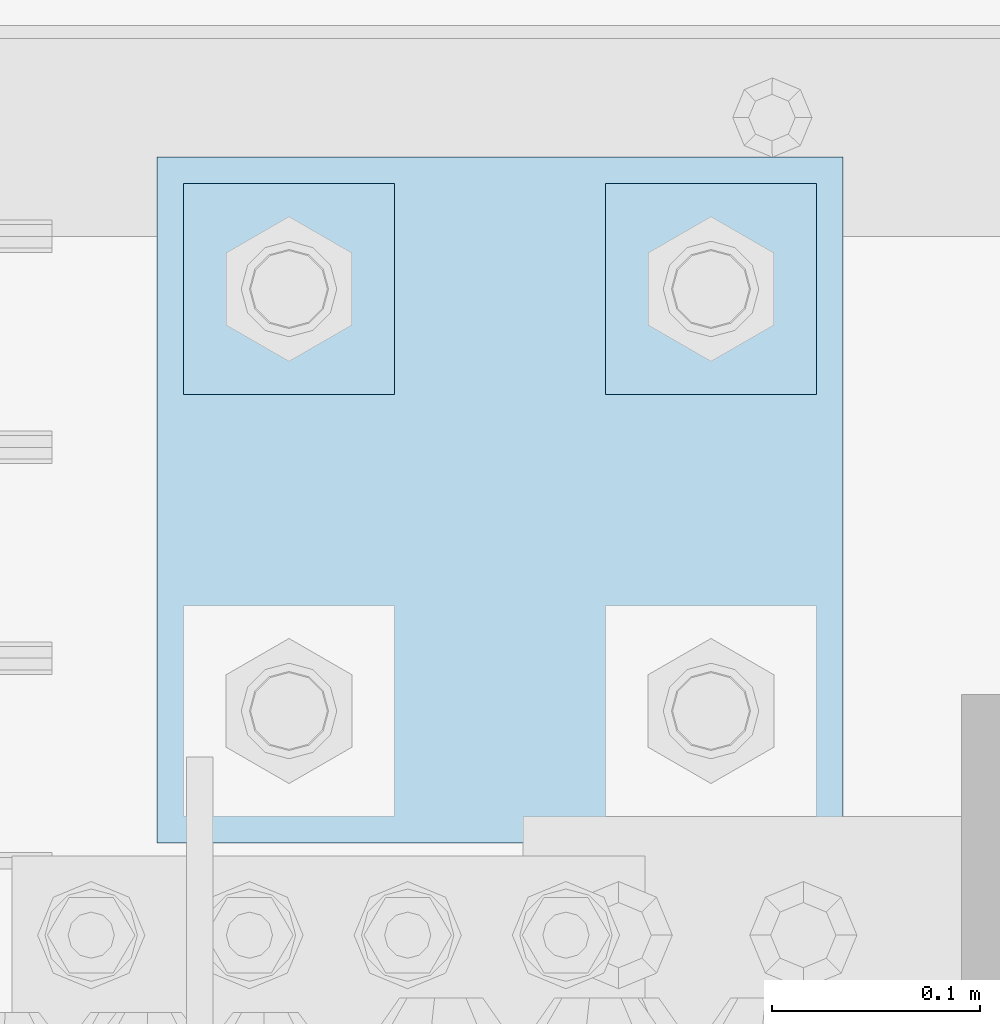
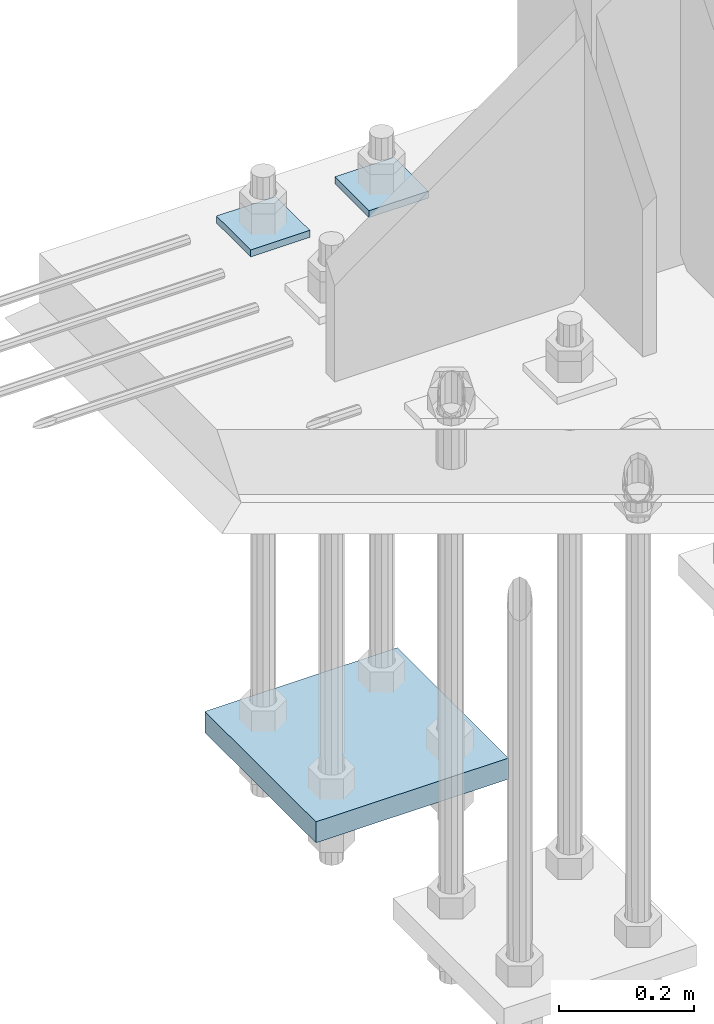
# One storey, part 3655 of 3843: 3 plates, 1 element without a shape of its own.
"""IFC2X3 building model written with IfcOpenShell, lengths in millimetres."""

from ifc_helpers import new_model, si_unit, frame, origin_with_axes, place, context, subcontext, project, spatial, faceted_brep, material, type_object, element, aggregate, save


model = new_model("IFC2X3")

# Units and contexts
model_context = context("Model", 3, precision=1e-05, world=origin_with_axes())
body_context = subcontext(model_context, "Body", "Model", "MODEL_VIEW")
ifc_project = project(units=[si_unit("LENGTHUNIT", "METRE", prefix="MILLI"), si_unit("AREAUNIT", "SQUARE_METRE"), si_unit("VOLUMEUNIT", "CUBIC_METRE"), si_unit("MASSUNIT", "GRAM", prefix="KILO"), si_unit("TIMEUNIT", "SECOND"), si_unit("PLANEANGLEUNIT", "RADIAN"), si_unit("SOLIDANGLEUNIT", "STERADIAN"), si_unit("THERMODYNAMICTEMPERATUREUNIT", "DEGREE_CELSIUS"), si_unit("LUMINOUSINTENSITYUNIT", "LUMEN")], contexts=[model_context])

# Site, building, storey
site_placement = place(None, origin_with_axes())
site = spatial("IfcSite", under=ifc_project, at=site_placement, CompositionType="ELEMENT")
building_placement = place(site_placement, origin_with_axes())
building = spatial("IfcBuilding", under=site, at=building_placement, Name="Undefined", CompositionType="ELEMENT")
storey_placement = place(building_placement, origin_with_axes())
storey = spatial("IfcBuildingStorey", under=building, at=storey_placement, Name="Undefined", CompositionType="ELEMENT", Elevation=0.0)

# Assembly, plates
assembly_placement = place(storey_placement, origin_with_axes())
assembly = element("IfcElementAssembly", 1, at=assembly_placement, inside=storey, Name="TEMPLATE", AssemblyPlace="NOTDEFINED", PredefinedType="RIGID_FRAME")
ifc_material = material(Name="STEEL/A572-50")
plate_type_1 = type_object("IfcPlateType", PredefinedType="NOTDEFINED")
plate_1_placement = place(assembly_placement, frame((85293.2, 104990.9, 29698.95), z_axis=(0.0, -1.0, 0.0), x_axis=(1.0, 0.0, 0.0)))
plate_1 = element("IfcPlate", 2, at=plate_1_placement, type_object=plate_type_1, material=ifc_material, Name="Washer Plate", context=body_context, shape_type="Brep", body=[
    faceted_brep([(0.0, -6.3499999046162, 0.0), (-1.67347025126219e-10, -6.35000000000582, 101.600000000151), (-1.67347025126219e-10, 6.35000000000582, 101.600000000151), (7.27595761418343e-12, 6.3499999046162, 0.0), (101.599998474121, -6.34999999999854, 101.599998474121), (101.599998474121, 6.34999999999854, 101.599998474121), (101.6, -6.34999999999854, 0.0), (101.6, 6.34999999999854, 0.0)], [[[0, 1, 2, 3]], [[1, 4, 5, 2]], [[4, 6, 7, 5]], [[6, 0, 3, 7]], [[5, 7, 3, 2]], [[6, 4, 1, 0]]]),
])
plate_2_placement = place(assembly_placement, frame((85090.0, 104990.9, 29698.95), z_axis=(0.0, -1.0, 0.0), x_axis=(1.0, 0.0, 0.0)))
plate_2 = element("IfcPlate", 3, at=plate_2_placement, type_object=plate_type_1, material=ifc_material, Name="Washer Plate", context=body_context, shape_type="Brep", body=[
    faceted_brep([(0.0, -6.3499999046162, 0.0), (-1.67347025126219e-10, -6.35000000000582, 101.600000000151), (-1.67347025126219e-10, 6.35000000000582, 101.600000000151), (7.27595761418343e-12, 6.3499999046162, 0.0), (101.599998474121, -6.34999999999854, 101.599998474121), (101.599998474121, 6.34999999999854, 101.599998474121), (101.6, -6.34999999999854, 0.0), (101.6, 6.34999999999854, 0.0)], [[[0, 1, 2, 3]], [[1, 4, 5, 2]], [[4, 6, 7, 5]], [[6, 0, 3, 7]], [[5, 7, 3, 2]], [[6, 4, 1, 0]]]),
])
plate_type_2 = type_object("IfcPlateType", PredefinedType="NOTDEFINED")
plate_3_placement = place(assembly_placement, frame((85077.3, 105003.600003052, 28784.55), z_axis=(1.0, 0.0, 0.0), x_axis=(0.0, -1.0, 0.0)))
plate_3 = element("IfcPlate", 4, at=plate_3_placement, type_object=plate_type_2, material=ifc_material, Name="PLATE", context=body_context, shape_type="Brep", body=[
    faceted_brep([(0.0, -19.0500000000029, 0.0), (0.0, -19.0499999999993, 330.200012207031), (0.0, 19.0499999999993, 330.200012207031), (0.0, 19.0500000000029, 0.0), (330.200012207031, -19.0499999999993, 330.200012207031), (330.200012207031, 19.0499999999993, 330.200012207031), (330.200012207031, -19.0499999999993, 0.0), (330.200012207031, 19.0499999999993, 0.0)], [[[0, 1, 2, 3]], [[1, 4, 5, 2]], [[4, 6, 7, 5]], [[6, 0, 3, 7]], [[5, 7, 3, 2]], [[6, 4, 1, 0]]]),
])
aggregate(assembly, [plate_3, plate_1, plate_2])

save(model, "model.ifc")
